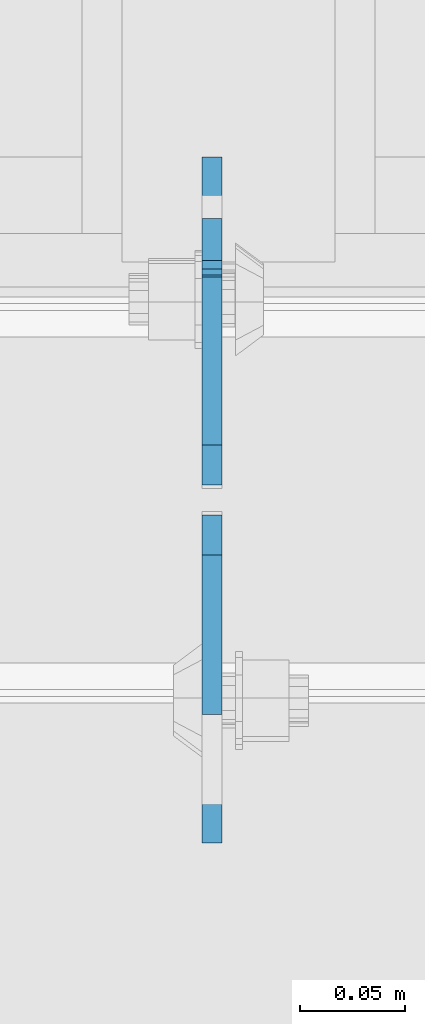
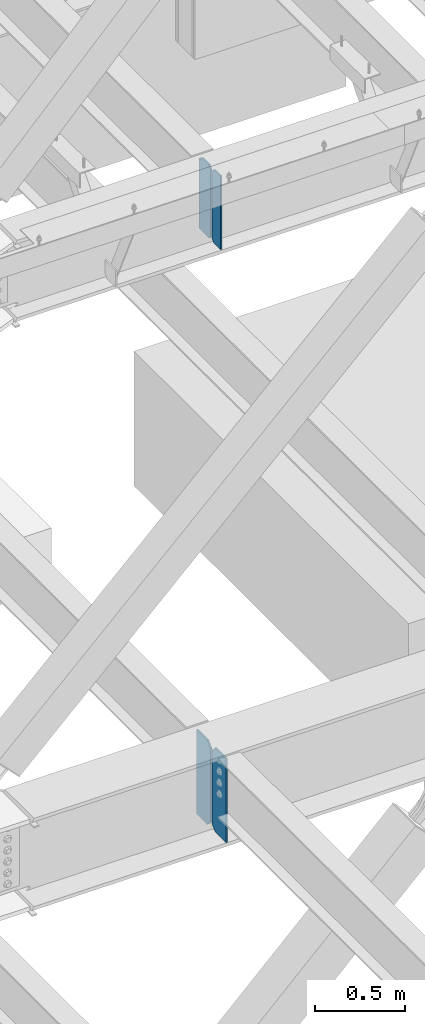
# One storey, part 1030 of 1179: 4 plates, 2 elements without a shape of their own.
"""IFC2X3 building model written with IfcOpenShell, lengths in millimetres."""

import ifcopenshell
import ifcopenshell.guid

model = None  # the IFC model being written
_history = None  # IfcOwnerHistory: only IFC2X3 demands one
_inside = {}  # id of a spatial element -> (the spatial element, [elements in it])
_under = {}  # id of a project, library or spatial element -> (it, [spatial elements below it])
_declared = {}  # id of a project -> (the project, [libraries it declares])
_typed = {}  # id of a type object -> (the type object, [elements of that type])
_made_of = {}  # id of a material, layer set ... -> (it, [elements and type objects made of it])


def new_model(schema):
    """Start an empty IFC model of exactly this schema.

    Asked for "IFC4X3", IfcOpenShell would pick the latest addendum, in which some entities
    have other attributes; the version numbers below select the first issue.
    IFC2X3 requires an IfcOwnerHistory on every rooted entity: one is made here for all.
    """
    global model, _history
    if schema == "IFC4X3":
        model = ifcopenshell.file(schema_version=(4, 3, 0, 0))
    else:
        model = ifcopenshell.file(schema=schema)
    _inside.clear()
    _under.clear()
    _declared.clear()
    _typed.clear()
    _made_of.clear()
    _history = None
    if model.schema == "IFC2X3":
        org = make("IfcOrganization", Name="unknown")
        user = make(
            "IfcPersonAndOrganization",
            ThePerson=make("IfcPerson", FamilyName="unknown"),
            TheOrganization=org,
        )
        app = make(
            "IfcApplication",
            ApplicationDeveloper=org,
            Version="unknown",
            ApplicationFullName="unknown",
            ApplicationIdentifier="unknown",
        )
        _history = make(
            "IfcOwnerHistory",
            OwningUser=user,
            OwningApplication=app,
            ChangeAction="ADDED",
            CreationDate=0,
        )
    return model


def make(cls, **values):
    """One entity of the class cls with the attributes given. An attribute that is None is left unset."""
    return model.create_entity(
        cls, **{name: value for name, value in values.items() if value is not None}
    )


def rooted(cls, **values):
    """An entity with a GlobalId (a new one), such as an element, a storey or a relation."""
    return make(cls, GlobalId=ifcopenshell.guid.new(), OwnerHistory=_history, **values)


def si_unit(unit_type, name, prefix=None):
    """IfcSIUnit, for example si_unit("LENGTHUNIT", "METRE", prefix="MILLI")."""
    return make("IfcSIUnit", UnitType=unit_type, Prefix=prefix, Name=name)


def assignment(units):
    """IfcUnitAssignment: the units of a project."""
    return None if units is None else make("IfcUnitAssignment", Units=units)


def point(xyz):
    """IfcCartesianPoint."""
    return None if xyz is None else make("IfcCartesianPoint", Coordinates=xyz)


def direction(xyz):
    """IfcDirection."""
    return None if xyz is None else make("IfcDirection", DirectionRatios=xyz)


def frame(location, z_axis=None, x_axis=None):
    """IfcAxis2Placement3D, a coordinate frame: its origin and axes. An axis left out is left unset."""
    return make(
        "IfcAxis2Placement3D",
        Location=point(location),
        Axis=direction(z_axis),
        RefDirection=direction(x_axis),
    )


def origin_with_axes():
    """The frame at (0, 0, 0) with the z axis (0, 0, 1) and the x axis (1, 0, 0) written out."""
    return frame((0.0, 0.0, 0.0), z_axis=(0.0, 0.0, 1.0), x_axis=(1.0, 0.0, 0.0))


def place(relative_to, where):
    """IfcLocalPlacement: puts the frame where relative to a parent placement (None: the world)."""
    return make(
        "IfcLocalPlacement", PlacementRelTo=relative_to, RelativePlacement=where
    )


def context(
    kind, dimensions, precision=None, world=None, true_north=None, identifier=None
):
    """IfcGeometricRepresentationContext, for example the 3D "Model" context."""
    return make(
        "IfcGeometricRepresentationContext",
        ContextIdentifier=identifier,
        ContextType=kind,
        CoordinateSpaceDimension=dimensions,
        Precision=precision,
        WorldCoordinateSystem=world,
        TrueNorth=true_north,
    )


def subcontext(parent, identifier, kind, view, scale=None):
    """IfcGeometricRepresentationSubContext, for example "Body" below "Model"."""
    return make(
        "IfcGeometricRepresentationSubContext",
        ContextIdentifier=identifier,
        ContextType=kind,
        ParentContext=parent,
        TargetScale=scale,
        TargetView=view,
    )


def project(units=None, contexts=None):
    """IfcProject with its units and contexts."""
    return rooted(
        "IfcProject",
        Name="project",
        RepresentationContexts=contexts,
        UnitsInContext=assignment(units),
    )


def spatial(cls, under=None, at=None, **own):
    """A site, building, storey or space (cls), placed at a placement, below another one or the project."""
    s = rooted(cls, ObjectPlacement=at, **own)
    if under is not None:
        _under.setdefault(under.id(), (under, []))[1].append(s)
    return s


def faces_of(points, faces, orient=None, outer=None):
    """IfcFace entities. A face is a list of loops; a loop is a list of indices into points, from 0.

    orient and outer hold one flag for each loop. By default every Orientation is true, the
    first loop of a face is its IfcFaceOuterBound and the others are IfcFaceBound.
    """
    made = []
    for i, loops in enumerate(faces):
        bounds = []
        for j, loop in enumerate(loops):
            is_outer = j == 0 if outer is None else outer[i][j]
            bounds.append(
                make(
                    "IfcFaceOuterBound" if is_outer else "IfcFaceBound",
                    Bound=make("IfcPolyLoop", Polygon=[points[k] for k in loop]),
                    Orientation=True if orient is None else orient[i][j],
                )
            )
        made.append(make("IfcFace", Bounds=bounds))
    return made


def faceted_brep(points, faces, orient=None, outer=None, voids=None):
    """IfcFacetedBrep: a solid bounded by flat faces; with voids (closed shells), ...WithVoids."""
    shared = [point(p) for p in points]
    hull = make("IfcClosedShell", CfsFaces=faces_of(shared, faces, orient, outer))
    if voids is None:
        return make("IfcFacetedBrep", Outer=hull)
    return make(
        "IfcFacetedBrepWithVoids",
        Outer=hull,
        Voids=[
            make(cls, CfsFaces=faces_of(shared, fs, o, b)) for cls, fs, o, b in voids
        ],
    )


def shape(context_of_items, identifier, shape_type, items):
    """IfcShapeRepresentation: the items that make up one representation, for example the "Body"."""
    return make(
        "IfcShapeRepresentation",
        ContextOfItems=context_of_items,
        RepresentationIdentifier=identifier,
        RepresentationType=shape_type,
        Items=items,
    )


def material(Name=None, Category=None):
    """IfcMaterial."""
    return make("IfcMaterial", Name=Name, Category=Category)


def made_of(thing, what):
    """Note that an element or type object is made of a material, layer set ...; save() writes the relation."""
    if what is not None:
        _made_of.setdefault(what.id(), (what, []))[1].append(thing)
    return thing


def type_object(cls, material=None, **own):
    """A type object (cls), such as IfcWallType, which elements share."""
    return made_of(rooted(cls, **own), material)


def element(
    cls,
    number,
    at=None,
    inside=None,
    cuts=None,
    type_object=None,
    material=None,
    context=None,
    identifier="Body",
    shape_type=None,
    held_by="IfcProductDefinitionShape",
    body=None,
    shapes=None,
    **own,
):
    """One element of the class cls, such as IfcWall. Its Tag is "e" and its number.

    at: its placement. inside: the storey or other place that contains it. cuts: it is an
    opening in that element (IfcRelVoidsElement). A single representation is given by context,
    identifier, shape_type and body (its items); several are given by shapes. held_by: the class
    of the entity that holds the representations. save() writes the other relations.
    """
    e = rooted(cls, Tag="e%d" % number, ObjectPlacement=at, **own)
    if body is not None:
        shapes = [shape(context, identifier, shape_type, body)]
    if shapes is not None:
        e.Representation = make(held_by, Representations=shapes)
    if inside is not None:
        _inside.setdefault(inside.id(), (inside, []))[1].append(e)
    if cuts is not None:
        rooted(
            "IfcRelVoidsElement", RelatingBuildingElement=cuts, RelatedOpeningElement=e
        )
    if type_object is not None:
        _typed.setdefault(type_object.id(), (type_object, []))[1].append(e)
    return made_of(e, material)


def aggregate(whole, parts):
    """IfcRelAggregates: a whole, such as a stair, and the parts it consists of."""
    return rooted("IfcRelAggregates", RelatingObject=whole, RelatedObjects=parts)


def save(model, path):
    """Write the relations noted so far, then the file.

    IfcRelAggregates (storeys below a building ...), IfcRelContainedInSpatialStructure (elements
    in a storey), IfcRelDefinesByType, IfcRelAssociatesMaterial and IfcRelDeclares: one each for
    every whole, place, type object, material and project.
    """
    for whole, parts in _under.values():
        aggregate(whole, parts)
    for where, things in _inside.values():
        rooted(
            "IfcRelContainedInSpatialStructure",
            RelatedElements=things,
            RelatingStructure=where,
        )
    for kind, things in _typed.values():
        rooted("IfcRelDefinesByType", RelatedObjects=things, RelatingType=kind)
    for what, things in _made_of.values():
        rooted("IfcRelAssociatesMaterial", RelatedObjects=things, RelatingMaterial=what)
    for by, libraries in _declared.values():
        rooted("IfcRelDeclares", RelatingContext=by, RelatedDefinitions=libraries)
    model.write(path)


model = new_model("IFC2X3")

# Units and contexts
model_context = context("Model", 3, precision=1e-05, world=origin_with_axes())
body_context = subcontext(model_context, "Body", "Model", "MODEL_VIEW")
ifc_project = project(units=[si_unit("LENGTHUNIT", "METRE", prefix="MILLI"), si_unit("AREAUNIT", "SQUARE_METRE"), si_unit("VOLUMEUNIT", "CUBIC_METRE"), si_unit("MASSUNIT", "GRAM", prefix="KILO"), si_unit("TIMEUNIT", "SECOND"), si_unit("PLANEANGLEUNIT", "RADIAN"), si_unit("SOLIDANGLEUNIT", "STERADIAN"), si_unit("THERMODYNAMICTEMPERATUREUNIT", "DEGREE_CELSIUS"), si_unit("LUMINOUSINTENSITYUNIT", "LUMEN")], contexts=[model_context])

# Site, building, storey
site_placement = place(None, origin_with_axes())
site = spatial("IfcSite", under=ifc_project, at=site_placement, CompositionType="ELEMENT")
building_placement = place(site_placement, origin_with_axes())
building = spatial("IfcBuilding", under=site, at=building_placement, Name="Undefined", CompositionType="ELEMENT")
storey_placement = place(building_placement, origin_with_axes())
storey = spatial("IfcBuildingStorey", under=building, at=storey_placement, Name="Undefined", CompositionType="ELEMENT", Elevation=0.0)

# Assembly, plates
assembly_1_placement = place(storey_placement, origin_with_axes())
assembly_1 = element("IfcElementAssembly", 1, at=assembly_1_placement, inside=storey, Name="BEAM", AssemblyPlace="NOTDEFINED", PredefinedType="RIGID_FRAME")
ifc_material = material(Name="STEEL/A36")
plate_type_1 = type_object("IfcPlateType", PredefinedType="NOTDEFINED")
plate_1_placement = place(assembly_1_placement, frame((10317.1620000839, 27058.14375, 7489.825), z_axis=(0.0, 0.0, 1.0), x_axis=(0.0, 1.0, 0.0)))
plate_1 = element("IfcPlate", 2, at=plate_1_placement, type_object=plate_type_1, material=ifc_material, Name="PLATE", context=body_context, shape_type="Brep", body=[
    faceted_brep([(99.2187497618652, -4.76249999998072, 498.475), (99.21875, -4.76250000000073, 492.124999809264), (99.21875, 4.76250000000073, 492.124999809264), (99.2187499999927, 4.76250000001892, 498.475), (100.185479922588, -4.76250000000073, 487.264920291219), (100.185479922588, 4.76250000000073, 487.264920291219), (102.938493823065, -4.76250000000073, 483.144743823065), (102.938493823065, 4.76250000000073, 483.144743823065), (107.058670291219, -4.76250000000073, 480.391729922587), (107.058670291219, 4.76250000000073, 480.391729922587), (111.918749809265, -4.76250000000073, 479.424999999999), (111.918749809265, 4.76250000000073, 479.424999999999), (127.000007629395, -4.76250000000073, 479.424999999999), (127.000004683803, 4.76250000000073, 479.424999999999), (0.0, -4.76250000000073, 479.425006866455), (19.0499992370605, -4.76250000000073, 498.475006103516), (19.0499992370605, 4.76250000000073, 498.475006103516), (0.0, 4.76250000000073, 479.425006866455), (0.0, -4.76250000000073, 19.0499992370605), (0.0, 4.76250000000073, 19.0499992370605), (19.0499992370605, -4.76250000000073, 0.0), (19.0499992370605, 4.76250000000073, 0.0), (127.0, -4.76250000000073, 0.0), (127.0, 4.76250000000073, 0.0)], [[[0, 1, 2, 3]], [[4, 5, 2, 1]], [[6, 7, 5, 4]], [[8, 9, 7, 6]], [[10, 11, 9, 8]], [[12, 13, 11, 10]], [[14, 15, 16, 17]], [[18, 14, 17, 19]], [[20, 18, 19, 21]], [[22, 20, 21, 23]], [[8, 6, 4, 1, 0, 15, 14, 18, 20, 22, 12, 10]], [[16, 15, 0, 3]], [[23, 21, 19, 17, 16, 3, 2, 5, 7, 9, 11, 13]], [[22, 23, 13, 12]]]),
])
plate_type_2 = type_object("IfcPlateType", PredefinedType="NOTDEFINED")
plate_2_placement = place(assembly_1_placement, frame((10317.1620000839, 27043.85625, 7489.825), z_axis=(0.0, 0.0, 1.0), x_axis=(0.0, -1.0, 0.0)))
plate_2 = element("IfcPlate", 3, at=plate_2_placement, type_object=plate_type_2, material=ifc_material, Name="PLATE", context=body_context, shape_type="Brep", body=[
    faceted_brep([(0.0, -4.76250000000073, 19.0499992370605), (0.0, -4.76250000000073, 479.425006866455), (0.0, 4.76250000000073, 479.425006866455), (0.0, 4.76250000000073, 19.0499992370605), (19.0499992370605, -4.76250000000073, 498.475006103516), (19.0499992370605, 4.76250000000073, 498.475006103516), (95.25, -4.76250000000073, 498.475006103516), (95.25, 4.76250000000073, 498.475006103516), (95.25, -4.76250000000073, 0.0), (95.25, 4.76250000000073, 0.0), (19.0499992370605, -4.76250000000073, 0.0), (19.0499992370605, 4.76250000000073, 0.0)], [[[0, 1, 2, 3]], [[1, 4, 5, 2]], [[4, 6, 7, 5]], [[6, 8, 9, 7]], [[8, 10, 11, 9]], [[10, 0, 3, 11]], [[5, 7, 9, 11, 3, 2]], [[10, 8, 6, 4, 1, 0]]]),
])
aggregate(assembly_1, [plate_2, plate_1])

assembly_2_placement = place(storey_placement, origin_with_axes())
assembly_2 = element("IfcElementAssembly", 4, at=assembly_2_placement, inside=storey, Name="BEAM", AssemblyPlace="NOTDEFINED", PredefinedType="RIGID_FRAME")
plate_type_3 = type_object("IfcPlateType", PredefinedType="NOTDEFINED")
plate_3_placement = place(assembly_2_placement, frame((10317.1621686935, 27043.0625000004, 3505.2), z_axis=(0.0, 0.0, 1.0), x_axis=(0.0, -1.0, 0.0)))
plate_3 = element("IfcPlate", 5, at=plate_3_placement, type_object=plate_type_3, material=ifc_material, Name="PLATE", context=body_context, shape_type="Brep", body=[
    faceted_brep([(0.0, -4.76250000000073, 34.9249999999993), (0.0, -4.76250000000073, 536.575000762939), (0.0, 4.76250000000073, 536.575000762939), (0.0, 4.76250000000073, 34.9249999999993), (34.9249992370605, -4.76250000000073, 571.5), (34.9249992370605, 4.76250000000073, 571.5), (155.575000000001, -4.76250000000073, 571.5), (155.575000000001, 4.76250000000073, 571.5), (155.575000000001, -4.76250000000073, 0.0), (155.575000000001, 4.76250000000073, 0.0), (34.9249992370715, -4.76249999996799, 0.0), (34.9249992370678, 4.76250000003347, 0.0)], [[[0, 1, 2, 3]], [[1, 4, 5, 2]], [[4, 6, 7, 5]], [[6, 8, 9, 7]], [[8, 10, 11, 9]], [[10, 0, 3, 11]], [[5, 7, 9, 11, 3, 2]], [[10, 8, 6, 4, 1, 0]]]),
])
plate_4_placement = place(assembly_2_placement, frame((10317.1621686935, 27058.9375, 3505.2), z_axis=(0.0, 0.0, 1.0), x_axis=(0.0, 1.0, 0.0)))
plate_4 = element("IfcPlate", 6, at=plate_4_placement, type_object=plate_type_3, material=ifc_material, Name="PLATE", context=body_context, shape_type="Brep", body=[
    faceted_brep([(0.0, -4.76250000000073, 34.9249999999993), (0.0, -4.76250000000073, 536.575000762939), (0.0, 4.76250000000073, 536.575000762939), (0.0, 4.76250000000073, 34.9249999999993), (34.9249992370605, -4.76250000000073, 571.5), (34.9249992370605, 4.76250000000073, 571.5), (155.575000000001, -4.76250000000073, 571.5), (155.575000000001, 4.76250000000073, 571.5), (155.575000000001, -4.76250000000073, 0.0), (155.575000000001, 4.76250000000073, 0.0), (34.9249992370715, -4.76249999996799, 0.0), (34.9249992370678, 4.76250000003347, 0.0)], [[[0, 1, 2, 3]], [[1, 4, 5, 2]], [[4, 6, 7, 5]], [[6, 8, 9, 7]], [[8, 10, 11, 9]], [[10, 0, 3, 11]], [[5, 7, 9, 11, 3, 2]], [[10, 8, 6, 4, 1, 0]]]),
])
aggregate(assembly_2, [plate_3, plate_4])

save(model, "model.ifc")
